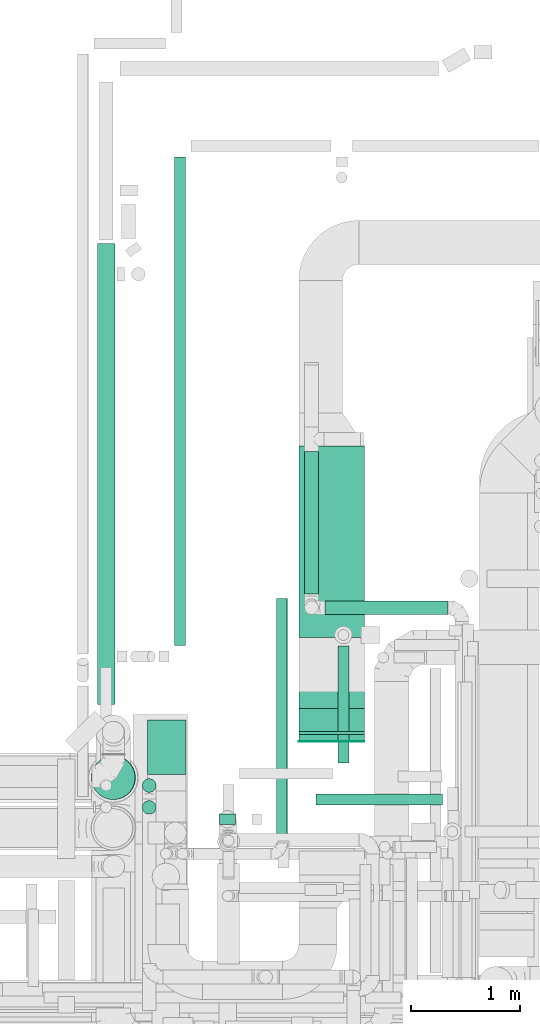
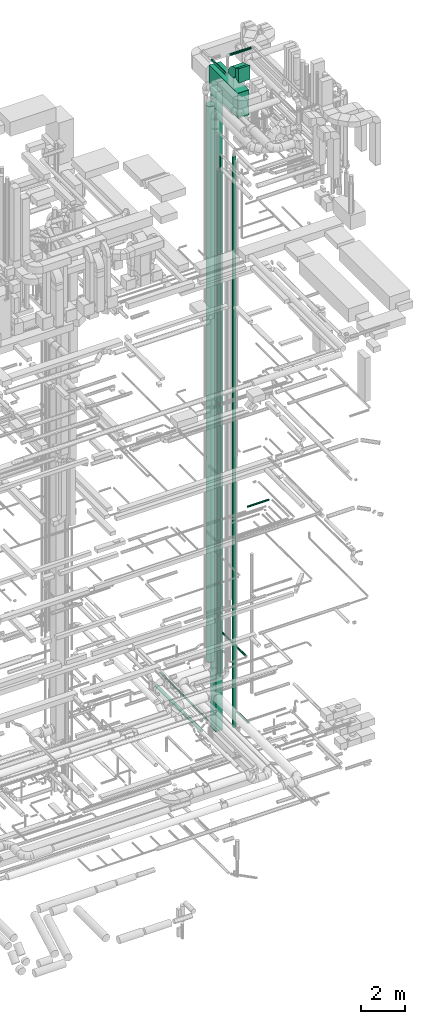
# One storey, part 71 of 337: 14 flow segments, 3 flow fittings.
"""IFC2X3 building model written with IfcOpenShell, lengths in millimetres."""

from ifc_helpers import new_model, entity, si_unit, converted_unit, derived_unit, direction, frame, frame_2d, origin, origin_2d_with_axis, place, context, subcontext, project, spatial, polyline, circle_curve, parameter, trimmed, segment, composite_curve, rectangle, circle, outline, extrude, source, transform, mapped, material, type_object, type_shapes, element, save


model = new_model("IFC2X3")

# Units and contexts
model_context = context("Model", 3, precision=0.01, world=origin(), true_north=direction((6.12303176911189e-17, 1.0)))
body_context = subcontext(model_context, "Body", "Model", "MODEL_VIEW")
ifc_project = project(units=[si_unit("LENGTHUNIT", "METRE", prefix="MILLI"), si_unit("AREAUNIT", "SQUARE_METRE"), si_unit("VOLUMEUNIT", "CUBIC_METRE"), converted_unit("PLANEANGLEUNIT", "DEGREE", entity("IfcRatioMeasure", 0.0174532925199433), si_unit("PLANEANGLEUNIT", "RADIAN"), dimensions=[0, 0, 0, 0, 0, 0, 0]), si_unit("MASSUNIT", "GRAM", prefix="KILO"), derived_unit("MASSDENSITYUNIT", [(si_unit("MASSUNIT", "GRAM", prefix="KILO"), 1), (si_unit("LENGTHUNIT", "METRE"), -3)]), derived_unit("MOMENTOFINERTIAUNIT", [(si_unit("LENGTHUNIT", "METRE"), 4)]), si_unit("TIMEUNIT", "SECOND"), si_unit("FREQUENCYUNIT", "HERTZ"), si_unit("THERMODYNAMICTEMPERATUREUNIT", "DEGREE_CELSIUS"), derived_unit("THERMALTRANSMITTANCEUNIT", [(si_unit("MASSUNIT", "GRAM", prefix="KILO"), 1), (si_unit("THERMODYNAMICTEMPERATUREUNIT", "KELVIN"), -1), (si_unit("TIMEUNIT", "SECOND"), -3)]), derived_unit("VOLUMETRICFLOWRATEUNIT", [(si_unit("LENGTHUNIT", "METRE"), 3), (si_unit("TIMEUNIT", "SECOND"), -1)]), derived_unit("MASSFLOWRATEUNIT", [(si_unit("MASSUNIT", "GRAM", prefix="KILO"), 1), (si_unit("TIMEUNIT", "SECOND"), -1)]), derived_unit("ROTATIONALFREQUENCYUNIT", [(si_unit("TIMEUNIT", "SECOND"), -1)]), si_unit("ELECTRICCURRENTUNIT", "AMPERE"), si_unit("ELECTRICVOLTAGEUNIT", "VOLT"), si_unit("POWERUNIT", "WATT"), si_unit("FORCEUNIT", "NEWTON", prefix="KILO"), si_unit("ILLUMINANCEUNIT", "LUX"), si_unit("LUMINOUSFLUXUNIT", "LUMEN"), si_unit("LUMINOUSINTENSITYUNIT", "CANDELA"), derived_unit("USERDEFINED", [(si_unit("MASSUNIT", "GRAM", prefix="KILO"), -1), (si_unit("LENGTHUNIT", "METRE"), -2), (si_unit("TIMEUNIT", "SECOND"), 3), (si_unit("LUMINOUSFLUXUNIT", "LUMEN"), 1)]), derived_unit("LINEARVELOCITYUNIT", [(si_unit("LENGTHUNIT", "METRE"), 1), (si_unit("TIMEUNIT", "SECOND"), -1)]), si_unit("PRESSUREUNIT", "PASCAL"), derived_unit("USERDEFINED", [(si_unit("LENGTHUNIT", "METRE"), -2), (si_unit("MASSUNIT", "GRAM", prefix="KILO"), 1), (si_unit("TIMEUNIT", "SECOND"), -2)]), derived_unit("LINEARFORCEUNIT", [(si_unit("MASSUNIT", "GRAM", prefix="KILO"), 1), (si_unit("LENGTHUNIT", "METRE"), 1), (si_unit("TIMEUNIT", "SECOND"), -2), (si_unit("LENGTHUNIT", "METRE"), -1)]), derived_unit("PLANARFORCEUNIT", [(si_unit("MASSUNIT", "GRAM", prefix="KILO"), 1), (si_unit("LENGTHUNIT", "METRE"), 1), (si_unit("TIMEUNIT", "SECOND"), -2), (si_unit("LENGTHUNIT", "METRE"), -2)])], contexts=[model_context])

# Site, building, storey
site_placement = place(None, origin())
site = spatial("IfcSite", under=ifc_project, at=site_placement, CompositionType="ELEMENT")
building_placement = place(site_placement, origin())
building = spatial("IfcBuilding", under=site, at=building_placement, CompositionType="ELEMENT")
storey_placement = place(building_placement, origin())
storey = spatial("IfcBuildingStorey", under=building, at=storey_placement, CompositionType="ELEMENT", Elevation=0.0)

# Flow segments
duct_segment_type_1 = type_object("IfcDuctSegmentType", PredefinedType="NOTDEFINED")
flow_segment_1_placement = place(storey_placement, frame((69255.37, 12578.52, 34980.0)))
element("IfcFlowSegment", 1, at=flow_segment_1_placement, inside=storey, type_object=duct_segment_type_1, context=body_context, shape_type="SweptSolid", body=[
    extrude(rectangle(XDim=4.99999999994689, YDim=600.000000000002, at=origin_2d_with_axis()), frame((300.0, 2.5, 0.0), z_axis=(0.0, 0.0, 1.0), x_axis=(0.0, 1.0, 0.0)), (0.0, 0.0, 1.0), 800.0),
])
flow_segment_2_placement = place(storey_placement, frame((67874.81, 12278.05, -720.11)))
element("IfcFlowSegment", 2, at=flow_segment_2_placement, inside=storey, type_object=duct_segment_type_1, context=body_context, shape_type="SweptSolid", body=[
    extrude(rectangle(XDim=499.999999999999, YDim=349.999999999998, at=origin_2d_with_axis()), frame((175.0, 250.0, 0.0), z_axis=(0.0, 0.0, 1.0), x_axis=(0.0, -1.0, 0.0)), (0.0, 0.0, 1.0), 35850.1092108574),
])
flow_segment_3_placement = place(storey_placement, frame((69255.37, 12670.87, 32950.0)))
element("IfcFlowSegment", 3, at=flow_segment_3_placement, inside=storey, type_object=duct_segment_type_1, context=body_context, shape_type="SweptSolid", body=[
    extrude(rectangle(XDim=2612.74299195141, YDim=600.000000000002, at=origin_2d_with_axis()), frame((300.0, 1306.37, 0.0), z_axis=(0.0, 0.0, 1.0), x_axis=(0.0, 1.0, 0.0)), (0.0, 0.0, 1.0), 1400.0),
])
flow_segment_4_placement = place(storey_placement, frame((68529.23, 11820.03, -450.0)))
element("IfcFlowSegment", 4, at=flow_segment_4_placement, inside=storey, type_object=duct_segment_type_1, context=body_context, shape_type="SweptSolid", body=[
    extrude(rectangle(XDim=150.000000000001, YDim=99.9999999999989, at=origin_2d_with_axis()), frame((75.0, 50.0, 0.0), z_axis=(0.0, 0.0, 1.0), x_axis=(-1.0, 0.0, 0.0)), (0.0, 0.0, 1.0), 31990.0),
])
duct_segment_type_2 = type_object("IfcDuctSegmentType", PredefinedType="NOTDEFINED")
flow_segment_5_placement = place(storey_placement, frame((69611.44, 12385.94, -951.6)))
element("IfcFlowSegment", 5, at=flow_segment_5_placement, inside=storey, type_object=duct_segment_type_2, context=body_context, shape_type="SweptSolid", body=[
    extrude(circle(Radius=50.0, at=origin_2d_with_axis()), frame((51.6, 0.0, 51.6), z_axis=(0.0, 1.0, 0.0), x_axis=(1.0, 0.0, 0.0)), (0.0, 0.0, 1.0), 1069.02838000002),
])
flow_segment_6_placement = place(storey_placement, frame((67412.61, 12917.82, -981.6)))
element("IfcFlowSegment", 6, at=flow_segment_6_placement, inside=storey, type_object=duct_segment_type_2, context=body_context, shape_type="SweptSolid", body=[
    extrude(circle(Radius=80.0, at=origin_2d_with_axis()), frame((81.6, 0.0, 81.6), z_axis=(0.0, 1.0, 0.0), x_axis=(1.0, 0.0, 0.0)), (0.0, 0.0, 1.0), 4214.22306685089),
])
flow_segment_7_placement = place(storey_placement, frame((68117.73, 13456.7, -951.6)))
element("IfcFlowSegment", 7, at=flow_segment_7_placement, inside=storey, type_object=duct_segment_type_2, context=body_context, shape_type="SweptSolid", body=[
    extrude(circle(Radius=50.0, at=origin_2d_with_axis()), frame((51.6, 0.0, 51.6), z_axis=(0.0, 1.0, 0.0), x_axis=(1.0, 0.0, 0.0)), (0.0, 0.0, 1.0), 4466.43443000001),
])
flow_segment_8_placement = place(storey_placement, frame((69413.1, 11999.21, 11448.4)))
element("IfcFlowSegment", 8, at=flow_segment_8_placement, inside=storey, type_object=duct_segment_type_2, context=body_context, shape_type="SweptSolid", body=[
    extrude(circle(Radius=50.0, at=origin_2d_with_axis()), frame((0.0, 51.6, 51.6), z_axis=(1.0, 0.0, 0.0), x_axis=(0.0, -1.0, 0.0)), (0.0, 0.0, 1.0), 1155.00000000001),
])
flow_segment_9_placement = place(storey_placement, frame((69050.03, 11654.29, 3448.4)))
element("IfcFlowSegment", 9, at=flow_segment_9_placement, inside=storey, type_object=duct_segment_type_2, context=body_context, shape_type="SweptSolid", body=[
    extrude(circle(Radius=50.0, at=origin_2d_with_axis()), frame((51.6, 0.0, 51.6), z_axis=(0.0, 1.0, 0.0), x_axis=(-1.0, 0.0, 0.0)), (0.0, 0.0, 1.0), 2234.99999999999),
])
flow_segment_10_placement = place(storey_placement, frame((69496.94, 13740.9, 35675.9)))
element("IfcFlowSegment", 10, at=flow_segment_10_placement, inside=storey, type_object=duct_segment_type_2, context=body_context, shape_type="SweptSolid", body=[
    extrude(circle(Radius=62.5, at=origin_2d_with_axis()), frame((0.0, 64.1, 64.1), z_axis=(1.0, 0.0, 0.0), x_axis=(0.0, -1.0, 0.0)), (0.0, 0.0, 1.0), 1122.64156377826),
])
flow_segment_11_placement = place(storey_placement, frame((69307.84, 13930.0, 34565.9)))
element("IfcFlowSegment", 11, at=flow_segment_11_placement, inside=storey, type_object=duct_segment_type_2, context=body_context, shape_type="SweptSolid", body=[
    extrude(circle(Radius=62.5, at=origin_2d_with_axis()), frame((64.1, 0.0, 64.1), z_axis=(0.0, 1.0, 0.0), x_axis=(1.0, 0.0, 0.0)), (0.0, 0.0, 1.0), 1302.50000000002),
])
flow_segment_12_placement = place(storey_placement, frame((67823.9, 12114.64, 2625.0)))
element("IfcFlowSegment", 12, at=flow_segment_12_placement, inside=storey, type_object=duct_segment_type_2, context=body_context, shape_type="SweptSolid", body=[
    extrude(circle(Radius=62.5, at=origin_2d_with_axis()), frame((64.1, 64.1, 0.0), z_axis=(0.0, 0.0, 1.0), x_axis=(-1.0, 0.0, 0.0)), (0.0, 0.0, 1.0), 30265.0),
])
flow_segment_13_placement = place(storey_placement, frame((67823.9, 11914.44, 2625.0)))
element("IfcFlowSegment", 13, at=flow_segment_13_placement, inside=storey, type_object=duct_segment_type_2, context=body_context, shape_type="SweptSolid", body=[
    extrude(circle(Radius=62.5, at=origin_2d_with_axis()), frame((64.1, 64.1, 0.0), z_axis=(0.0, 0.0, 1.0), x_axis=(-1.0, 0.0, 0.0)), (0.0, 0.0, 1.0), 29140.0),
])
flow_segment_14_placement = place(storey_placement, frame((67357.51, 12048.32, 3450.03)))
element("IfcFlowSegment", 14, at=flow_segment_14_placement, inside=storey, type_object=duct_segment_type_2, context=body_context, shape_type="SweptSolid", body=[
    extrude(circle(Radius=200.0, at=origin_2d_with_axis()), frame((205.7, 201.6, 0.03), z_axis=(-0.000131785563679762, 0.0, 0.999999991316283), x_axis=(-0.999999991316283, 0.0, -0.000131785563679762)), (0.0, 0.0, 1.0), 31149.9469683989),
])

# Flow fittings
ifc_material = material()
duct_fitting_type_1 = type_object("IfcDuctFittingType", PredefinedType="NOTDEFINED", material=ifc_material)
shared_shape_1 = source(origin(), body_context, "Body", "SweptSolid", [
    extrude(outline(polyline([(-313.05, -290.69), (22.36, -290.69), (245.97, 156.52), (44.72, 424.85), (-313.05, -290.69)])), frame((150.0, -300.0, 0.0), z_axis=(0.0, 1.0, 0.0), x_axis=(0.89442719099988, 0.0, -0.447213595500029)), (0.0, 0.0, 1.0), 600.0),
])
type_shapes(duct_fitting_type_1, [shared_shape_1])
flow_fitting_1_placement = place(storey_placement, frame((69555.37, 12583.52, 35380.0), z_axis=(0.0, 0.0, 1.0), x_axis=(0.0, 1.0, 0.0)))
element("IfcFlowFitting", 15, at=flow_fitting_1_placement, inside=storey, type_object=duct_fitting_type_1, material=ifc_material, context=body_context, shape_type="MappedRepresentation", body=[
    mapped(shared_shape_1, transform((0.0, 0.0, 0.0), scale=1.0)),
])
duct_fitting_type_2 = type_object("IfcDuctFittingType", PredefinedType="NOTDEFINED", material=ifc_material)
shared_shape_2 = source(origin(), body_context, "Body", "SweptSolid", [
    extrude(rectangle(XDim=24.9999999999999, YDim=600.0, at=origin_2d_with_axis()), frame((12.5, 0.0, -700.0)), (0.0, 0.0, 1.0), 1400.0),
])
type_shapes(duct_fitting_type_2, [shared_shape_2])
flow_fitting_2_placement = place(storey_placement, frame((69555.37, 12670.87, 33650.0), z_axis=(0.0, 0.0, 1.0), x_axis=(0.0, -1.0, 0.0)))
element("IfcFlowFitting", 16, at=flow_fitting_2_placement, inside=storey, type_object=duct_fitting_type_2, material=ifc_material, context=body_context, shape_type="MappedRepresentation", body=[
    mapped(shared_shape_2, transform((0.0, 0.0, 0.0), scale=1.0)),
])
duct_fitting_type_3 = type_object("IfcDuctFittingType", PredefinedType="NOTDEFINED", material=ifc_material)
shared_shape_3 = source(origin(), body_context, "Body", "SweptSolid", [
    extrude(outline(composite_curve([segment(polyline([(-450.0, -200.0), (50.0, -200.0)]), True, "CONTINUOUS"), segment(trimmed(circle_curve(frame_2d((200.0, -200.0), x_axis=(0.0, 1.0)), 150.0), [parameter(0.0)], [parameter(90.0000000000001)], True, "PARAMETER"), False, "CONTINUOUS"), segment(polyline([(200.0, -50.0), (200.0, 450.0)]), True, "CONTINUOUS"), segment(trimmed(circle_curve(frame_2d((200.0, -200.0), x_axis=(0.0, 1.0)), 650.0), [parameter(0.0)], [parameter(90.0000000000001)], True, "PARAMETER"), True, "CONTINUOUS")], self_intersect=False)), frame((-200.0, 200.0, -300.0), z_axis=(0.0, 0.0, 1.0), x_axis=(-1.0, 0.0, 0.0)), (0.0, 0.0, 1.0), 600.0),
])
type_shapes(duct_fitting_type_3, [shared_shape_3])
flow_fitting_3_placement = place(storey_placement, frame((69555.37, 13283.52, 35380.0), z_axis=(-1.0, 0.0, 0.0), x_axis=(0.0, 1.0, 0.0)))
element("IfcFlowFitting", 17, at=flow_fitting_3_placement, inside=storey, type_object=duct_fitting_type_3, material=ifc_material, context=body_context, shape_type="MappedRepresentation", body=[
    mapped(shared_shape_3, transform((0.0, 0.0, 0.0), scale=1.0)),
])

save(model, "model.ifc")
